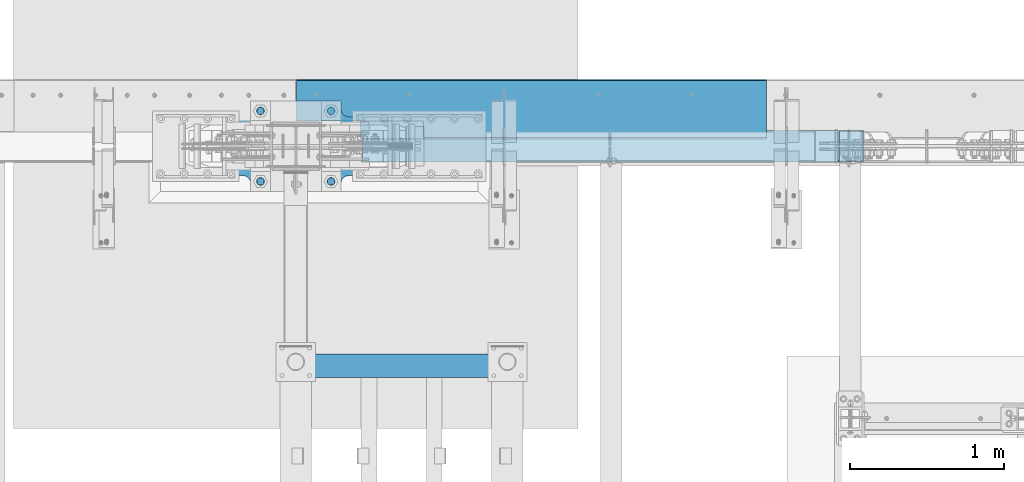
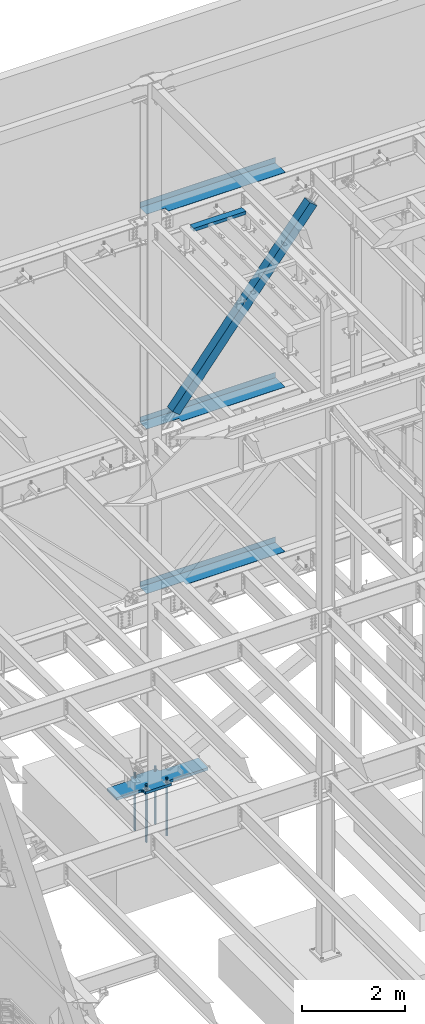
# One storey, part 770 of 1179: 9 beams, 1 member, 7 elements without a shape of their own.
"""IFC2X3 building model written with IfcOpenShell, lengths in millimetres."""

from ifc_helpers import new_model, si_unit, frame, origin_with_axes, place, context, subcontext, project, spatial, faceted_brep, material, type_object, element, aggregate, save


model = new_model("IFC2X3")

# Units and contexts
model_context = context("Model", 3, precision=1e-05, world=origin_with_axes())
body_context = subcontext(model_context, "Body", "Model", "MODEL_VIEW")
ifc_project = project(units=[si_unit("LENGTHUNIT", "METRE", prefix="MILLI"), si_unit("AREAUNIT", "SQUARE_METRE"), si_unit("VOLUMEUNIT", "CUBIC_METRE"), si_unit("MASSUNIT", "GRAM", prefix="KILO"), si_unit("TIMEUNIT", "SECOND"), si_unit("PLANEANGLEUNIT", "RADIAN"), si_unit("SOLIDANGLEUNIT", "STERADIAN"), si_unit("THERMODYNAMICTEMPERATUREUNIT", "DEGREE_CELSIUS"), si_unit("LUMINOUSINTENSITYUNIT", "LUMEN")], contexts=[model_context])

# Site, building, storey
site_placement = place(None, origin_with_axes())
site = spatial("IfcSite", under=ifc_project, at=site_placement, CompositionType="ELEMENT")
building_placement = place(site_placement, origin_with_axes())
building = spatial("IfcBuilding", under=site, at=building_placement, Name="Undefined", CompositionType="ELEMENT")
storey_placement = place(building_placement, origin_with_axes())
storey = spatial("IfcBuildingStorey", under=building, at=storey_placement, Name="Undefined", CompositionType="ELEMENT", Elevation=0.0)

# Assembly, beam
assembly_1_placement = place(storey_placement, origin_with_axes())
assembly_1 = element("IfcElementAssembly", 1, at=assembly_1_placement, inside=storey, Name="BEAM", AssemblyPlace="NOTDEFINED", PredefinedType="RIGID_FRAME")
ifc_material_1 = material(Name="STEEL/A36")
beam_type_1 = type_object("IfcBeamType", PredefinedType="NOTDEFINED")
beam_1_placement = place(assembly_1_placement, frame((9807.575, 41244.838, 13122.275), z_axis=(-1.0, 0.0, 0.0), x_axis=(0.0, 1.0, 0.0)))
beam_1 = element("IfcBeam", 2, at=beam_1_placement, type_object=beam_type_1, material=ifc_material_1, Name="BENT_PLATE", context=body_context, shape_type="Brep", body=[
    faceted_brep([(117.474499999989, -3.17499999999927, 1108.48200312289), (117.474499999989, 3.17499999999927, 1108.48200312289), (0.0, 3.17499999999927, 1108.48200312289), (0.0, -3.17499999999927, 1108.48200312289), (117.474497999712, -3.17499999999927, 1524.0), (117.474497999712, 3.17499999999927, 1524.0), (379.411999999997, -3.17499999999927, -1524.0), (0.0, -3.17499999999927, -1524.0), (0.0, 3.17499999999927, -1524.0), (385.762000000002, 3.17499999999927, -1524.0), (385.762000000002, -130.175000000001, -1524.0), (379.411999999997, -130.175000000001, -1524.0), (385.762000000002, 3.17499999999927, 1524.0), (385.762000000002, -130.175000000001, 1524.0), (379.411999999997, -130.175000000001, 1524.0), (379.411999999997, -3.17499999999927, 1524.0)], [[[0, 1, 2, 3]], [[4, 5, 1, 0]], [[6, 7, 8, 9, 10, 11]], [[9, 12, 13, 10]], [[14, 11, 10, 13]], [[15, 6, 11, 14]], [[3, 7, 6, 15, 4, 0]], [[8, 7, 3, 2]], [[12, 9, 8, 2, 1, 5]], [[15, 14, 13, 12, 5, 4]]]),
])
aggregate(assembly_1, [beam_1])

assembly_2_placement = place(storey_placement, origin_with_axes())
assembly_2 = element("IfcElementAssembly", 3, at=assembly_2_placement, inside=storey, Name="BEAM", AssemblyPlace="NOTDEFINED", PredefinedType="RIGID_FRAME")
beam_type_2 = type_object("IfcBeamType", PredefinedType="NOTDEFINED")
beam_2_placement = place(assembly_2_placement, frame((9807.575, 41627.425, 4235.45000610352), z_axis=(1.0, 0.0, 0.0), x_axis=(0.0, 0.0, -1.0)))
beam_2 = element("IfcBeam", 4, at=beam_2_placement, type_object=beam_type_2, material=ifc_material_1, Name="BENT_PLATE", context=body_context, shape_type="Brep", body=[
    faceted_brep([(133.350006103513, -265.112499984869, -699.560460443527), (127.000006103513, -265.112499984869, -699.560460443527), (127.000006103513, -265.112500000461, -1524.0), (133.350006103513, -265.112500000461, -1524.0), (133.350006103513, -373.062499984873, -699.56046044747), (127.000006103513, -373.062500000007, -699.56046044747), (0.0, 3.17499999999927, -1524.0), (6.00266503170133e-10, 3.17500000077416, 1524.00000000052), (133.350006103513, 3.17500000000291, 1524.0), (133.350006103513, 3.17500000000291, -1524.0), (0.0, -3.17499999999927, -1524.0), (6.00266503170133e-10, -3.17499999922438, 1524.00000000052), (127.000006103513, -3.17500000000291, -1524.0), (127.000006103513, -3.17500000000291, 1524.0), (127.000006103513, -373.062500000007, 1524.0), (133.350006103513, -373.062500000007, 1524.0)], [[[0, 1, 2, 3]], [[4, 5, 1, 0]], [[6, 7, 8, 9]], [[10, 11, 7, 6]], [[11, 10, 12, 13]], [[8, 7, 11, 13, 14, 15]], [[3, 9, 8, 15, 4, 0]], [[12, 10, 6, 9, 3, 2]], [[14, 13, 12, 2, 1, 5]], [[15, 14, 5, 4]]]),
])
aggregate(assembly_2, [beam_2])

assembly_3_placement = place(storey_placement, origin_with_axes())
assembly_3 = element("IfcElementAssembly", 5, at=assembly_3_placement, inside=storey, Name="BEAM", AssemblyPlace="NOTDEFINED", PredefinedType="RIGID_FRAME")
beam_3_placement = place(assembly_3_placement, frame((9807.575, 41627.425, 8147.05000610352), z_axis=(1.0, 0.0, 0.0), x_axis=(0.0, 0.0, -1.0)))
beam_3 = element("IfcBeam", 6, at=beam_3_placement, type_object=beam_type_2, material=ifc_material_1, Name="BENT_PLATE", context=body_context, shape_type="Brep", body=[
    faceted_brep([(133.350006103513, -265.112499985182, -799.803584542169), (127.000006103513, -265.112499985182, -799.803584542169), (127.000006103513, -265.112500000461, -1524.0), (133.350006103513, -265.112500000461, -1524.0), (133.350006103513, -373.062499985186, -799.80358454572), (127.000006103513, -373.062500000007, -799.80358454572), (0.0, 3.17499999999927, -1524.0), (6.00266503170133e-10, 3.17500000077416, 1524.00000000052), (133.350006103513, 3.17500000000291, 1524.0), (133.350006103513, 3.17500000000291, -1524.0), (0.0, -3.17499999999927, -1524.0), (6.00266503170133e-10, -3.17499999922438, 1524.00000000052), (127.000006103513, -3.17500000000291, -1524.0), (127.000006103513, -3.17500000000291, 1524.0), (127.000006103513, -373.062500000007, 1524.0), (133.350006103513, -373.062500000007, 1524.0)], [[[0, 1, 2, 3]], [[4, 5, 1, 0]], [[6, 7, 8, 9]], [[10, 11, 7, 6]], [[11, 10, 12, 13]], [[8, 7, 11, 13, 14, 15]], [[3, 9, 8, 15, 4, 0]], [[12, 10, 6, 9, 3, 2]], [[14, 13, 12, 2, 1, 5]], [[15, 14, 5, 4]]]),
])
aggregate(assembly_3, [beam_3])

# Assembly, member
assembly_4_placement = place(storey_placement, origin_with_axes())
assembly_4 = element("IfcElementAssembly", 7, at=assembly_4_placement, inside=storey, Name="None", AssemblyPlace="NOTDEFINED", PredefinedType="RIGID_FRAME")
ifc_material_2 = material(Name="STEEL/A992")
member_type = type_object("IfcMemberType", Name="HSS8X8X3/16", PredefinedType="NOTDEFINED")
member_placement = place(assembly_4_placement, frame((8790.98756262445, 41198.8, 8381.65756353055), z_axis=(0.0, -1.0, 0.0), x_axis=(0.622099916714251, 0.0, 0.782937860640372)))
member = element("IfcMember", 8, at=member_placement, type_object=member_type, material=ifc_material_2, Name="None", ObjectType="HSS8X8X3/16", context=body_context, shape_type="Brep", body=[
    faceted_brep([(-3.63797880709171e-12, 96.8374999999978, -96.8375000000015), (-3.63797880709171e-12, -96.8374999999978, -96.8375000000015), (4965.25424181688, -96.8375000011438, -96.8375000000015), (4965.25424181692, 96.8374999988555, -96.8375000000015), (-3.63797880709171e-12, -96.8374999999978, 96.8375000000015), (4965.25424181688, -96.8375000011438, 96.8375000000015), (-3.63797880709171e-12, 96.8374999999978, 96.8375000000015), (4965.25424181692, 96.8374999988555, 96.8375000000015), (-3.63797880709171e-12, 101.599999999999, -101.599999999999), (-3.63797880709171e-12, 101.599999999999, 101.599999999999), (4965.25424181692, 101.599999998856, 101.599999999999), (4965.25424181692, 101.599999998856, -101.599999999999), (0.0, -101.599999999999, 101.599999999999), (4965.25424181688, -101.600000001145, 101.599999999999), (0.0, -101.599999999999, -101.599999999999), (4965.25424181688, -101.600000001145, -101.599999999999)], [[[0, 1, 2, 3]], [[1, 4, 5, 2]], [[4, 6, 7, 5]], [[6, 0, 3, 7]], [[8, 9, 10, 11]], [[9, 12, 13, 10]], [[12, 14, 15, 13]], [[14, 8, 11, 15]], [[13, 15, 11, 10], [5, 7, 3, 2]], [[14, 12, 9, 8], [6, 4, 1, 0]]]),
])
aggregate(assembly_4, [member])

# Assembly, beam
assembly_5_placement = place(storey_placement, origin_with_axes())
assembly_5 = element("IfcElementAssembly", 9, at=assembly_5_placement, inside=storey, Name="FRAME", AssemblyPlace="NOTDEFINED", PredefinedType="RIGID_FRAME")
ifc_material_3 = material()
beam_type_3 = type_object("IfcBeamType", Name="HSS6X3X1/4", PredefinedType="NOTDEFINED")
beam_4_placement = place(assembly_5_placement, frame((8382.0, 39775.7344873485, 13722.35), z_axis=(0.0, -1.0, 0.0), x_axis=(1.0, 0.0, 0.0)))
beam_4 = element("IfcBeam", 10, at=beam_4_placement, type_object=beam_type_3, material=ifc_material_3, Name="BEAM", ObjectType="HSS6X3X1/4", context=body_context, shape_type="Brep", body=[
    faceted_brep([(0.0, 31.75, -69.8499999999985), (0.0, -31.75, -69.8499999999985), (1168.4, -31.75, -69.8499999999985), (1168.4, 31.75, -69.8499999999985), (0.0, -31.75, 69.8499999999985), (1168.4, -31.75, 69.8499999999985), (0.0, 31.75, 69.8499999999985), (1168.4, 31.75, 69.8499999999985), (0.0, 38.0999999999985, -76.1999999999998), (0.0, 38.0999999999985, 76.1999999999998), (1168.4, 38.1000000000004, 76.1999999999971), (1168.4, 38.1000000000004, -76.1999999999971), (0.0, -38.0999999999985, 76.1999999999998), (1168.4, -38.1000000000004, 76.1999999999971), (0.0, -38.0999999999985, -76.1999999999998), (1168.4, -38.1000000000004, -76.1999999999971)], [[[0, 1, 2, 3]], [[1, 4, 5, 2]], [[4, 6, 7, 5]], [[6, 0, 3, 7]], [[8, 9, 10, 11]], [[9, 12, 13, 10]], [[12, 14, 15, 13]], [[14, 8, 11, 15]], [[13, 15, 11, 10], [5, 7, 3, 2]], [[14, 12, 9, 8], [6, 4, 1, 0]]]),
])
aggregate(assembly_5, [beam_4])

# Assembly, beams
assembly_6_placement = place(storey_placement, origin_with_axes())
assembly_6 = element("IfcElementAssembly", 11, at=assembly_6_placement, inside=storey, Name="TEMPLATE", AssemblyPlace="NOTDEFINED", PredefinedType="RIGID_FRAME")
ifc_material_4 = material(Name="STEEL/F1554-GR.55")
beam_type_4 = type_object("IfcBeamType", PredefinedType="NOTDEFINED")
beam_5_placement = place(assembly_6_placement, frame((8051.80000000001, 41427.4, -355.6), z_axis=(0.0, -1.0, 0.0), x_axis=(0.0, 0.0, -1.0)))
beam_5 = element("IfcBeam", 12, at=beam_5_placement, type_object=beam_type_4, material=ifc_material_4, Name="ANCHOR_ROD", context=body_context, shape_type="Brep", body=[
    faceted_brep([(-257.175, -21.2176223927199, 12.25), (-257.175, -12.25, 21.2176223927163), (-257.175, 0.0, 24.5), (-257.175, 12.25, 21.2176223927163), (-257.175, 21.2176223927199, 12.25), (-257.175, 24.5, 0.0), (-257.175, 21.2176223927199, -12.25), (-257.175, 12.25, -21.2176223927163), (-257.175, 0.0, -24.5), (-257.175, -12.25, -21.2176223927163), (-257.175, -21.2176223927199, -12.25), (-257.175, -24.5, 0.0), (0.0, 24.5, 0.0), (0.0, 21.2176223927163, -12.25), (0.0, 12.25, -21.217622392719), (0.0, 0.0, -24.5), (0.0, -12.25, -21.217622392719), (0.0, -21.2176223927163, -12.25), (0.0, -24.5, 0.0), (0.0, -21.2176223927163, 12.25), (0.0, -12.25, 21.217622392719), (0.0, 0.0, 24.5), (0.0, 12.25, 21.217622392719), (0.0, 21.2176223927163, 12.25), (0.0, -23.466540125788, 9.72015918207308), (0.0, -17.9605122421417, 17.9605122421381), (0.0, -9.72015918207035, 23.4665401257871), (0.0, 0.0, 25.3999999999996), (0.0, 9.72015918207035, 23.4665401257871), (0.0, 17.9605122421417, 17.9605122421381), (0.0, 23.466540125788, 9.72015918207308), (0.0, 25.4000000000015, 0.0), (0.0, 23.466540125788, -9.72015918207308), (0.0, 17.9605122421417, -17.9605122421381), (0.0, 9.72015918207035, -23.4665401257871), (0.0, 0.0, -25.3999999999996), (0.0, -9.72015918207035, -23.4665401257871), (0.0, -17.9605122421417, -17.9605122421381), (0.0, -23.466540125788, -9.72015918207308), (0.0, -25.4000000000015, 0.0), (946.149999999999, -25.4000000000015, 0.0), (946.149999999999, -23.466540125788, 9.72015918207308), (946.149999999999, -17.9605122421417, 17.9605122421381), (946.149999999999, -9.72015918207035, 23.4665401257871), (946.149999999999, 0.0, 25.3999999999996), (946.149999999999, 9.72015918207035, 23.4665401257871), (946.149999999999, 17.9605122421417, 17.9605122421381), (946.149999999999, 23.466540125788, 9.72015918207308), (946.149999999999, 25.4000000000015, 0.0), (946.149999999999, 23.466540125788, -9.72015918207308), (946.149999999999, 17.9605122421417, -17.9605122421381), (946.149999999999, 9.72015918207035, -23.4665401257871), (946.149999999999, 0.0, -25.3999999999996), (946.149999999999, -9.72015918207035, -23.4665401257871), (946.149999999999, -17.9605122421417, -17.9605122421381), (946.149999999999, -23.466540125788, -9.72015918207308), (946.149999999999, -12.2499999999927, 21.217622392719), (946.149999999999, 7.27595761418343e-12, 24.5), (946.149999999999, 12.2500000000073, 21.217622392719), (946.149999999999, 21.2176223927236, 12.25), (946.149999999999, 24.5000000000073, 0.0), (946.149999999999, 21.2176223927236, -12.25), (946.149999999999, 12.2500000000073, -21.217622392719), (946.149999999999, 7.27595761418343e-12, -24.5), (946.149999999999, -12.2499999999927, -21.217622392719), (946.149999999999, -21.217622392709, -12.25), (946.149999999999, -24.4999999999927, 0.0), (946.149999999999, -21.217622392709, 12.25), (1117.6, -12.2499999999927, -21.217622392719), (1117.6, 7.27595761418343e-12, -24.5), (1117.6, 12.2500000000073, -21.217622392719), (1117.6, 21.2176223927236, -12.25), (1117.6, 24.5000000000073, 0.0), (1117.6, 21.2176223927236, 12.25), (1117.6, 12.2500000000073, 21.217622392719), (1117.6, 7.27595761418343e-12, 24.5), (1117.6, -12.2499999999927, 21.217622392719), (1117.6, -21.217622392709, 12.25), (1117.6, -24.4999999999927, 0.0), (1117.6, -21.217622392709, -12.25)], [[[0, 1, 2, 3, 4, 5, 6, 7, 8, 9, 10, 11]], [[6, 5, 12, 13]], [[7, 6, 13, 14]], [[8, 7, 14, 15]], [[9, 8, 15, 16]], [[10, 9, 16, 17]], [[11, 10, 17, 18]], [[0, 11, 18, 19]], [[1, 0, 19, 20]], [[2, 1, 20, 21]], [[3, 2, 21, 22]], [[4, 3, 22, 23]], [[5, 4, 23, 12]], [[24, 25, 26, 27, 28, 29, 30, 31, 32, 33, 34, 35, 36, 37, 38, 39], [22, 21, 20, 19, 18, 17, 16, 15, 14, 13, 12, 23]], [[24, 39, 40, 41]], [[25, 24, 41, 42]], [[26, 25, 42, 43]], [[27, 26, 43, 44]], [[28, 27, 44, 45]], [[29, 28, 45, 46]], [[30, 29, 46, 47]], [[31, 30, 47, 48]], [[32, 31, 48, 49]], [[33, 32, 49, 50]], [[34, 33, 50, 51]], [[35, 34, 51, 52]], [[36, 35, 52, 53]], [[37, 36, 53, 54]], [[38, 37, 54, 55]], [[39, 38, 55, 40]], [[54, 53, 52, 51, 50, 49, 48, 47, 46, 45, 44, 43, 42, 41, 40, 55], [56, 57, 58, 59, 60, 61, 62, 63, 64, 65, 66, 67]], [[68, 69, 70, 71, 72, 73, 74, 75, 76, 77, 78, 79]], [[76, 75, 57, 56]], [[77, 76, 56, 67]], [[78, 77, 67, 66]], [[79, 78, 66, 65]], [[68, 79, 65, 64]], [[69, 68, 64, 63]], [[70, 69, 63, 62]], [[71, 70, 62, 61]], [[72, 71, 61, 60]], [[73, 72, 60, 59]], [[74, 73, 59, 58]], [[75, 74, 58, 57]]]),
])
beam_6_placement = place(assembly_6_placement, frame((8051.80000000001, 40970.2, -355.6), z_axis=(0.0, -1.0, 0.0), x_axis=(0.0, 0.0, -1.0)))
beam_6 = element("IfcBeam", 13, at=beam_6_placement, type_object=beam_type_4, material=ifc_material_4, Name="ANCHOR_ROD", context=body_context, shape_type="Brep", body=[
    faceted_brep([(-257.175, -21.2176223927199, 12.25), (-257.175, -12.25, 21.2176223927163), (-257.175, 0.0, 24.5), (-257.175, 12.25, 21.2176223927163), (-257.175, 21.2176223927199, 12.25), (-257.175, 24.5, 0.0), (-257.175, 21.2176223927199, -12.25), (-257.175, 12.25, -21.2176223927163), (-257.175, 0.0, -24.5), (-257.175, -12.25, -21.2176223927163), (-257.175, -21.2176223927199, -12.25), (-257.175, -24.5, 0.0), (0.0, 24.5, 0.0), (0.0, 21.2176223927163, -12.25), (0.0, 12.25, -21.217622392719), (0.0, 0.0, -24.5), (0.0, -12.25, -21.217622392719), (0.0, -21.2176223927163, -12.25), (0.0, -24.5, 0.0), (0.0, -21.2176223927163, 12.25), (0.0, -12.25, 21.217622392719), (0.0, 0.0, 24.5), (0.0, 12.25, 21.217622392719), (0.0, 21.2176223927163, 12.25), (0.0, -23.466540125788, 9.72015918207308), (0.0, -17.9605122421417, 17.9605122421381), (0.0, -9.72015918207035, 23.4665401257871), (0.0, 0.0, 25.3999999999996), (0.0, 9.72015918207035, 23.4665401257871), (0.0, 17.9605122421417, 17.9605122421381), (0.0, 23.466540125788, 9.72015918207308), (0.0, 25.4000000000015, 0.0), (0.0, 23.466540125788, -9.72015918207308), (0.0, 17.9605122421417, -17.9605122421381), (0.0, 9.72015918207035, -23.4665401257871), (0.0, 0.0, -25.3999999999996), (0.0, -9.72015918207035, -23.4665401257871), (0.0, -17.9605122421417, -17.9605122421381), (0.0, -23.466540125788, -9.72015918207308), (0.0, -25.4000000000015, 0.0), (946.149999999999, -25.4000000000015, 0.0), (946.149999999999, -23.466540125788, 9.72015918207308), (946.149999999999, -17.9605122421417, 17.9605122421381), (946.149999999999, -9.72015918207035, 23.4665401257871), (946.149999999999, 0.0, 25.3999999999996), (946.149999999999, 9.72015918207035, 23.4665401257871), (946.149999999999, 17.9605122421417, 17.9605122421381), (946.149999999999, 23.466540125788, 9.72015918207308), (946.149999999999, 25.4000000000015, 0.0), (946.149999999999, 23.466540125788, -9.72015918207308), (946.149999999999, 17.9605122421417, -17.9605122421381), (946.149999999999, 9.72015918207035, -23.4665401257871), (946.149999999999, 0.0, -25.3999999999996), (946.149999999999, -9.72015918207035, -23.4665401257871), (946.149999999999, -17.9605122421417, -17.9605122421381), (946.149999999999, -23.466540125788, -9.72015918207308), (946.149999999999, -12.2499999999927, 21.217622392719), (946.149999999999, 7.27595761418343e-12, 24.5), (946.149999999999, 12.2500000000073, 21.217622392719), (946.149999999999, 21.2176223927236, 12.25), (946.149999999999, 24.5000000000073, 0.0), (946.149999999999, 21.2176223927236, -12.25), (946.149999999999, 12.2500000000073, -21.217622392719), (946.149999999999, 7.27595761418343e-12, -24.5), (946.149999999999, -12.2499999999927, -21.217622392719), (946.149999999999, -21.217622392709, -12.25), (946.149999999999, -24.4999999999927, 0.0), (946.149999999999, -21.217622392709, 12.25), (1117.6, -12.2499999999927, -21.217622392719), (1117.6, 7.27595761418343e-12, -24.5), (1117.6, 12.2500000000073, -21.217622392719), (1117.6, 21.2176223927236, -12.25), (1117.6, 24.5000000000073, 0.0), (1117.6, 21.2176223927236, 12.25), (1117.6, 12.2500000000073, 21.217622392719), (1117.6, 7.27595761418343e-12, 24.5), (1117.6, -12.2499999999927, 21.217622392719), (1117.6, -21.217622392709, 12.25), (1117.6, -24.4999999999927, 0.0), (1117.6, -21.217622392709, -12.25)], [[[0, 1, 2, 3, 4, 5, 6, 7, 8, 9, 10, 11]], [[6, 5, 12, 13]], [[7, 6, 13, 14]], [[8, 7, 14, 15]], [[9, 8, 15, 16]], [[10, 9, 16, 17]], [[11, 10, 17, 18]], [[0, 11, 18, 19]], [[1, 0, 19, 20]], [[2, 1, 20, 21]], [[3, 2, 21, 22]], [[4, 3, 22, 23]], [[5, 4, 23, 12]], [[24, 25, 26, 27, 28, 29, 30, 31, 32, 33, 34, 35, 36, 37, 38, 39], [22, 21, 20, 19, 18, 17, 16, 15, 14, 13, 12, 23]], [[24, 39, 40, 41]], [[25, 24, 41, 42]], [[26, 25, 42, 43]], [[27, 26, 43, 44]], [[28, 27, 44, 45]], [[29, 28, 45, 46]], [[30, 29, 46, 47]], [[31, 30, 47, 48]], [[32, 31, 48, 49]], [[33, 32, 49, 50]], [[34, 33, 50, 51]], [[35, 34, 51, 52]], [[36, 35, 52, 53]], [[37, 36, 53, 54]], [[38, 37, 54, 55]], [[39, 38, 55, 40]], [[54, 53, 52, 51, 50, 49, 48, 47, 46, 45, 44, 43, 42, 41, 40, 55], [56, 57, 58, 59, 60, 61, 62, 63, 64, 65, 66, 67]], [[68, 69, 70, 71, 72, 73, 74, 75, 76, 77, 78, 79]], [[76, 75, 57, 56]], [[77, 76, 56, 67]], [[78, 77, 67, 66]], [[79, 78, 66, 65]], [[68, 79, 65, 64]], [[69, 68, 64, 63]], [[70, 69, 63, 62]], [[71, 70, 62, 61]], [[72, 71, 61, 60]], [[73, 72, 60, 59]], [[74, 73, 59, 58]], [[75, 74, 58, 57]]]),
])
beam_7_placement = place(assembly_6_placement, frame((8509.00000000001, 41427.4, -355.6), z_axis=(0.0, 1.0, 0.0), x_axis=(0.0, 0.0, -1.0)))
beam_7 = element("IfcBeam", 14, at=beam_7_placement, type_object=beam_type_4, material=ifc_material_4, Name="ANCHOR_ROD", context=body_context, shape_type="Brep", body=[
    faceted_brep([(-257.175, -21.2176223927199, 12.25), (-257.175, -12.25, 21.2176223927163), (-257.175, 0.0, 24.5), (-257.175, 12.25, 21.2176223927163), (-257.175, 21.2176223927199, 12.25), (-257.175, 24.5, 0.0), (-257.175, 21.2176223927199, -12.25), (-257.175, 12.25, -21.2176223927163), (-257.175, 0.0, -24.5), (-257.175, -12.25, -21.2176223927163), (-257.175, -21.2176223927199, -12.25), (-257.175, -24.5, 0.0), (0.0, 24.5, 0.0), (0.0, 21.2176223927163, -12.25), (0.0, 12.25, -21.217622392719), (0.0, 0.0, -24.5), (0.0, -12.25, -21.217622392719), (0.0, -21.2176223927163, -12.25), (0.0, -24.5, 0.0), (0.0, -21.2176223927163, 12.25), (0.0, -12.25, 21.217622392719), (0.0, 0.0, 24.5), (0.0, 12.25, 21.217622392719), (0.0, 21.2176223927163, 12.25), (0.0, -23.466540125788, 9.72015918207308), (0.0, -17.9605122421417, 17.9605122421381), (0.0, -9.72015918207035, 23.4665401257871), (0.0, 0.0, 25.3999999999996), (0.0, 9.72015918207035, 23.4665401257871), (0.0, 17.9605122421417, 17.9605122421381), (0.0, 23.466540125788, 9.72015918207308), (0.0, 25.4000000000015, 0.0), (0.0, 23.466540125788, -9.72015918207308), (0.0, 17.9605122421417, -17.9605122421381), (0.0, 9.72015918207035, -23.4665401257871), (0.0, 0.0, -25.3999999999996), (0.0, -9.72015918207035, -23.4665401257871), (0.0, -17.9605122421417, -17.9605122421381), (0.0, -23.466540125788, -9.72015918207308), (0.0, -25.4000000000015, 0.0), (946.149999999999, -25.4000000000015, 0.0), (946.149999999999, -23.466540125788, 9.72015918207308), (946.149999999999, -17.9605122421417, 17.9605122421381), (946.149999999999, -9.72015918207035, 23.4665401257871), (946.149999999999, 0.0, 25.3999999999996), (946.149999999999, 9.72015918207035, 23.4665401257871), (946.149999999999, 17.9605122421417, 17.9605122421381), (946.149999999999, 23.466540125788, 9.72015918207308), (946.149999999999, 25.4000000000015, 0.0), (946.149999999999, 23.466540125788, -9.72015918207308), (946.149999999999, 17.9605122421417, -17.9605122421381), (946.149999999999, 9.72015918207035, -23.4665401257871), (946.149999999999, 0.0, -25.3999999999996), (946.149999999999, -9.72015918207035, -23.4665401257871), (946.149999999999, -17.9605122421417, -17.9605122421381), (946.149999999999, -23.466540125788, -9.72015918207308), (946.149999999999, -12.2499999999927, 21.217622392719), (946.149999999999, 7.27595761418343e-12, 24.5), (946.149999999999, 12.2500000000073, 21.217622392719), (946.149999999999, 21.2176223927236, 12.25), (946.149999999999, 24.5000000000073, 0.0), (946.149999999999, 21.2176223927236, -12.25), (946.149999999999, 12.2500000000073, -21.217622392719), (946.149999999999, 7.27595761418343e-12, -24.5), (946.149999999999, -12.2499999999927, -21.217622392719), (946.149999999999, -21.217622392709, -12.25), (946.149999999999, -24.4999999999927, 0.0), (946.149999999999, -21.217622392709, 12.25), (1117.6, -12.2499999999927, -21.217622392719), (1117.6, 7.27595761418343e-12, -24.5), (1117.6, 12.2500000000073, -21.217622392719), (1117.6, 21.2176223927236, -12.25), (1117.6, 24.5000000000073, 0.0), (1117.6, 21.2176223927236, 12.25), (1117.6, 12.2500000000073, 21.217622392719), (1117.6, 7.27595761418343e-12, 24.5), (1117.6, -12.2499999999927, 21.217622392719), (1117.6, -21.217622392709, 12.25), (1117.6, -24.4999999999927, 0.0), (1117.6, -21.217622392709, -12.25)], [[[0, 1, 2, 3, 4, 5, 6, 7, 8, 9, 10, 11]], [[6, 5, 12, 13]], [[7, 6, 13, 14]], [[8, 7, 14, 15]], [[9, 8, 15, 16]], [[10, 9, 16, 17]], [[11, 10, 17, 18]], [[0, 11, 18, 19]], [[1, 0, 19, 20]], [[2, 1, 20, 21]], [[3, 2, 21, 22]], [[4, 3, 22, 23]], [[5, 4, 23, 12]], [[24, 25, 26, 27, 28, 29, 30, 31, 32, 33, 34, 35, 36, 37, 38, 39], [22, 21, 20, 19, 18, 17, 16, 15, 14, 13, 12, 23]], [[24, 39, 40, 41]], [[25, 24, 41, 42]], [[26, 25, 42, 43]], [[27, 26, 43, 44]], [[28, 27, 44, 45]], [[29, 28, 45, 46]], [[30, 29, 46, 47]], [[31, 30, 47, 48]], [[32, 31, 48, 49]], [[33, 32, 49, 50]], [[34, 33, 50, 51]], [[35, 34, 51, 52]], [[36, 35, 52, 53]], [[37, 36, 53, 54]], [[38, 37, 54, 55]], [[39, 38, 55, 40]], [[54, 53, 52, 51, 50, 49, 48, 47, 46, 45, 44, 43, 42, 41, 40, 55], [56, 57, 58, 59, 60, 61, 62, 63, 64, 65, 66, 67]], [[68, 69, 70, 71, 72, 73, 74, 75, 76, 77, 78, 79]], [[76, 75, 57, 56]], [[77, 76, 56, 67]], [[78, 77, 67, 66]], [[79, 78, 66, 65]], [[68, 79, 65, 64]], [[69, 68, 64, 63]], [[70, 69, 63, 62]], [[71, 70, 62, 61]], [[72, 71, 61, 60]], [[73, 72, 60, 59]], [[74, 73, 59, 58]], [[75, 74, 58, 57]]]),
])
beam_8_placement = place(assembly_6_placement, frame((8509.00000000001, 40970.2, -355.6), z_axis=(0.0, 1.0, 0.0), x_axis=(0.0, 0.0, -1.0)))
beam_8 = element("IfcBeam", 15, at=beam_8_placement, type_object=beam_type_4, material=ifc_material_4, Name="ANCHOR_ROD", context=body_context, shape_type="Brep", body=[
    faceted_brep([(-257.175, -21.2176223927199, 12.25), (-257.175, -12.25, 21.2176223927163), (-257.175, 0.0, 24.5), (-257.175, 12.25, 21.2176223927163), (-257.175, 21.2176223927199, 12.25), (-257.175, 24.5, 0.0), (-257.175, 21.2176223927199, -12.25), (-257.175, 12.25, -21.2176223927163), (-257.175, 0.0, -24.5), (-257.175, -12.25, -21.2176223927163), (-257.175, -21.2176223927199, -12.25), (-257.175, -24.5, 0.0), (0.0, 24.5, 0.0), (0.0, 21.2176223927163, -12.25), (0.0, 12.25, -21.217622392719), (0.0, 0.0, -24.5), (0.0, -12.25, -21.217622392719), (0.0, -21.2176223927163, -12.25), (0.0, -24.5, 0.0), (0.0, -21.2176223927163, 12.25), (0.0, -12.25, 21.217622392719), (0.0, 0.0, 24.5), (0.0, 12.25, 21.217622392719), (0.0, 21.2176223927163, 12.25), (0.0, -23.466540125788, 9.72015918207308), (0.0, -17.9605122421417, 17.9605122421381), (0.0, -9.72015918207035, 23.4665401257871), (0.0, 0.0, 25.3999999999996), (0.0, 9.72015918207035, 23.4665401257871), (0.0, 17.9605122421417, 17.9605122421381), (0.0, 23.466540125788, 9.72015918207308), (0.0, 25.4000000000015, 0.0), (0.0, 23.466540125788, -9.72015918207308), (0.0, 17.9605122421417, -17.9605122421381), (0.0, 9.72015918207035, -23.4665401257871), (0.0, 0.0, -25.3999999999996), (0.0, -9.72015918207035, -23.4665401257871), (0.0, -17.9605122421417, -17.9605122421381), (0.0, -23.466540125788, -9.72015918207308), (0.0, -25.4000000000015, 0.0), (946.149999999999, -25.4000000000015, 0.0), (946.149999999999, -23.466540125788, 9.72015918207308), (946.149999999999, -17.9605122421417, 17.9605122421381), (946.149999999999, -9.72015918207035, 23.4665401257871), (946.149999999999, 0.0, 25.3999999999996), (946.149999999999, 9.72015918207035, 23.4665401257871), (946.149999999999, 17.9605122421417, 17.9605122421381), (946.149999999999, 23.466540125788, 9.72015918207308), (946.149999999999, 25.4000000000015, 0.0), (946.149999999999, 23.466540125788, -9.72015918207308), (946.149999999999, 17.9605122421417, -17.9605122421381), (946.149999999999, 9.72015918207035, -23.4665401257871), (946.149999999999, 0.0, -25.3999999999996), (946.149999999999, -9.72015918207035, -23.4665401257871), (946.149999999999, -17.9605122421417, -17.9605122421381), (946.149999999999, -23.466540125788, -9.72015918207308), (946.149999999999, -12.2499999999927, 21.217622392719), (946.149999999999, 7.27595761418343e-12, 24.5), (946.149999999999, 12.2500000000073, 21.217622392719), (946.149999999999, 21.2176223927236, 12.25), (946.149999999999, 24.5000000000073, 0.0), (946.149999999999, 21.2176223927236, -12.25), (946.149999999999, 12.2500000000073, -21.217622392719), (946.149999999999, 7.27595761418343e-12, -24.5), (946.149999999999, -12.2499999999927, -21.217622392719), (946.149999999999, -21.217622392709, -12.25), (946.149999999999, -24.4999999999927, 0.0), (946.149999999999, -21.217622392709, 12.25), (1117.6, -12.2499999999927, -21.217622392719), (1117.6, 7.27595761418343e-12, -24.5), (1117.6, 12.2500000000073, -21.217622392719), (1117.6, 21.2176223927236, -12.25), (1117.6, 24.5000000000073, 0.0), (1117.6, 21.2176223927236, 12.25), (1117.6, 12.2500000000073, 21.217622392719), (1117.6, 7.27595761418343e-12, 24.5), (1117.6, -12.2499999999927, 21.217622392719), (1117.6, -21.217622392709, 12.25), (1117.6, -24.4999999999927, 0.0), (1117.6, -21.217622392709, -12.25)], [[[0, 1, 2, 3, 4, 5, 6, 7, 8, 9, 10, 11]], [[6, 5, 12, 13]], [[7, 6, 13, 14]], [[8, 7, 14, 15]], [[9, 8, 15, 16]], [[10, 9, 16, 17]], [[11, 10, 17, 18]], [[0, 11, 18, 19]], [[1, 0, 19, 20]], [[2, 1, 20, 21]], [[3, 2, 21, 22]], [[4, 3, 22, 23]], [[5, 4, 23, 12]], [[24, 25, 26, 27, 28, 29, 30, 31, 32, 33, 34, 35, 36, 37, 38, 39], [22, 21, 20, 19, 18, 17, 16, 15, 14, 13, 12, 23]], [[24, 39, 40, 41]], [[25, 24, 41, 42]], [[26, 25, 42, 43]], [[27, 26, 43, 44]], [[28, 27, 44, 45]], [[29, 28, 45, 46]], [[30, 29, 46, 47]], [[31, 30, 47, 48]], [[32, 31, 48, 49]], [[33, 32, 49, 50]], [[34, 33, 50, 51]], [[35, 34, 51, 52]], [[36, 35, 52, 53]], [[37, 36, 53, 54]], [[38, 37, 54, 55]], [[39, 38, 55, 40]], [[54, 53, 52, 51, 50, 49, 48, 47, 46, 45, 44, 43, 42, 41, 40, 55], [56, 57, 58, 59, 60, 61, 62, 63, 64, 65, 66, 67]], [[68, 69, 70, 71, 72, 73, 74, 75, 76, 77, 78, 79]], [[76, 75, 57, 56]], [[77, 76, 56, 67]], [[78, 77, 67, 66]], [[79, 78, 66, 65]], [[68, 79, 65, 64]], [[69, 68, 64, 63]], [[70, 69, 63, 62]], [[71, 70, 62, 61]], [[72, 71, 61, 60]], [[73, 72, 60, 59]], [[74, 73, 59, 58]], [[75, 74, 58, 57]]]),
])
aggregate(assembly_6, [beam_5, beam_6, beam_7, beam_8])

# Assembly, beam
assembly_7_placement = place(storey_placement, origin_with_axes())
assembly_7 = element("IfcElementAssembly", 16, at=assembly_7_placement, inside=storey, Name="COLUMN", AssemblyPlace="NOTDEFINED", PredefinedType="RIGID_FRAME")
ifc_material_5 = material(Name="STEEL/A572-GR.50")
beam_type_5 = type_object("IfcBeamType", PredefinedType="NOTDEFINED")
beam_9_placement = place(assembly_7_placement, frame((7404.10050354004, 41198.8, -247.65), z_axis=(0.0, 1.0, 0.0), x_axis=(1.0, 0.0, 0.0)))
beam_9 = element("IfcBeam", 17, at=beam_9_placement, type_object=beam_type_5, material=ifc_material_5, context=body_context, shape_type="Brep", body=[
    faceted_brep([(533.399497222894, -31.75, 190.500001526299), (533.399497222894, 31.75, 190.500001526299), (0.0, 31.75, 190.500001526299), (0.0, -31.75, 190.500001526299), (552.839815295076, -31.75, 194.36692121665), (552.839815295076, 31.75, 194.36692121665), (569.32052116769, -31.75, 205.37897681856), (569.32052116769, 31.75, 205.37897681856), (580.332576769603, -31.75, 221.859682691174), (580.332576769603, 31.75, 221.859682691174), (584.199496459958, -31.75, 241.30000076336), (584.199496459958, 31.75, 241.30000076336), (584.199496459958, -31.75, 292.1), (584.199496459958, 31.75, 292.1), (0.0, -31.75, -190.500001526299), (0.0, 31.75, -190.500001526299), (533.399497222894, 31.75, -190.500001526299), (533.399497222894, -31.75, -190.500001526299), (552.839815295076, 31.75, -194.36692121665), (552.839815295076, -31.75, -194.36692121665), (569.32052116769, 31.75, -205.37897681856), (569.32052116769, -31.75, -205.37897681856), (580.332576769603, 31.75, -221.859682691174), (580.332576769603, -31.75, -221.859682691174), (584.199496459958, 31.75, -241.30000076336), (584.199496459958, -31.75, -241.30000076336), (584.199496459958, 31.75, -292.1), (584.199496459958, -31.75, -292.1), (1168.39949645996, 31.75, -292.099999999999), (1168.39949645996, -31.75, -292.099999999999), (1168.39949645996, 31.75, -241.30000076336), (1168.39949645996, -31.75, -241.30000076336), (1172.26641615031, 31.75, -221.859682691174), (1172.26641615031, -31.75, -221.859682691174), (1183.27847175222, 31.75, -205.37897681856), (1183.27847175222, -31.75, -205.37897681856), (1199.75917762483, 31.75, -194.36692121665), (1199.75917762483, -31.75, -194.36692121665), (1219.19949569702, 31.75, -190.500001526299), (1219.19949569702, -31.75, -190.500001526299), (2057.39949645996, -31.75, -190.500001526299), (2057.39949645996, 31.75, -190.500001526299), (2057.39949645996, 31.75, 190.500001526299), (2057.39949645996, -31.75, 190.500001526299), (1219.19949569702, 31.75, 190.500001526299), (1219.19949569702, -31.75, 190.500001526299), (1199.75917762483, 31.75, 194.36692121665), (1199.75917762483, -31.75, 194.36692121665), (1183.27847175222, 31.75, 205.37897681856), (1183.27847175222, -31.75, 205.37897681856), (1172.26641615031, 31.75, 221.859682691174), (1172.26641615031, -31.75, 221.859682691174), (1168.39949645996, 31.75, 241.30000076336), (1168.39949645996, -31.75, 241.30000076336), (1168.39949645996, -31.75, 292.099999999999), (1168.39949645996, 31.75, 292.099999999999)], [[[0, 1, 2, 3]], [[4, 5, 1, 0]], [[6, 7, 5, 4]], [[8, 9, 7, 6]], [[10, 11, 9, 8]], [[12, 13, 11, 10]], [[14, 15, 16, 17]], [[17, 16, 18, 19]], [[19, 18, 20, 21]], [[21, 20, 22, 23]], [[23, 22, 24, 25]], [[25, 24, 26, 27]], [[28, 29, 27, 26]], [[29, 28, 30, 31]], [[31, 30, 32, 33]], [[33, 32, 34, 35]], [[35, 34, 36, 37]], [[37, 36, 38, 39]], [[40, 39, 38, 41]], [[40, 41, 42, 43]], [[43, 42, 44, 45]], [[45, 44, 46, 47]], [[47, 46, 48, 49]], [[49, 48, 50, 51]], [[51, 50, 52, 53]], [[54, 53, 52, 55]], [[8, 6, 4, 0, 3, 14, 17, 19, 21, 23, 25, 27, 29, 31, 33, 35, 37, 39, 40, 43, 45, 47, 49, 51, 53, 54, 12, 10]], [[15, 14, 3, 2]], [[55, 52, 50, 48, 46, 44, 42, 41, 38, 36, 34, 32, 30, 28, 26, 24, 22, 20, 18, 16, 15, 2, 1, 5, 7, 9, 11, 13]], [[54, 55, 13, 12]]]),
])
aggregate(assembly_7, [beam_9])

save(model, "model.ifc")
